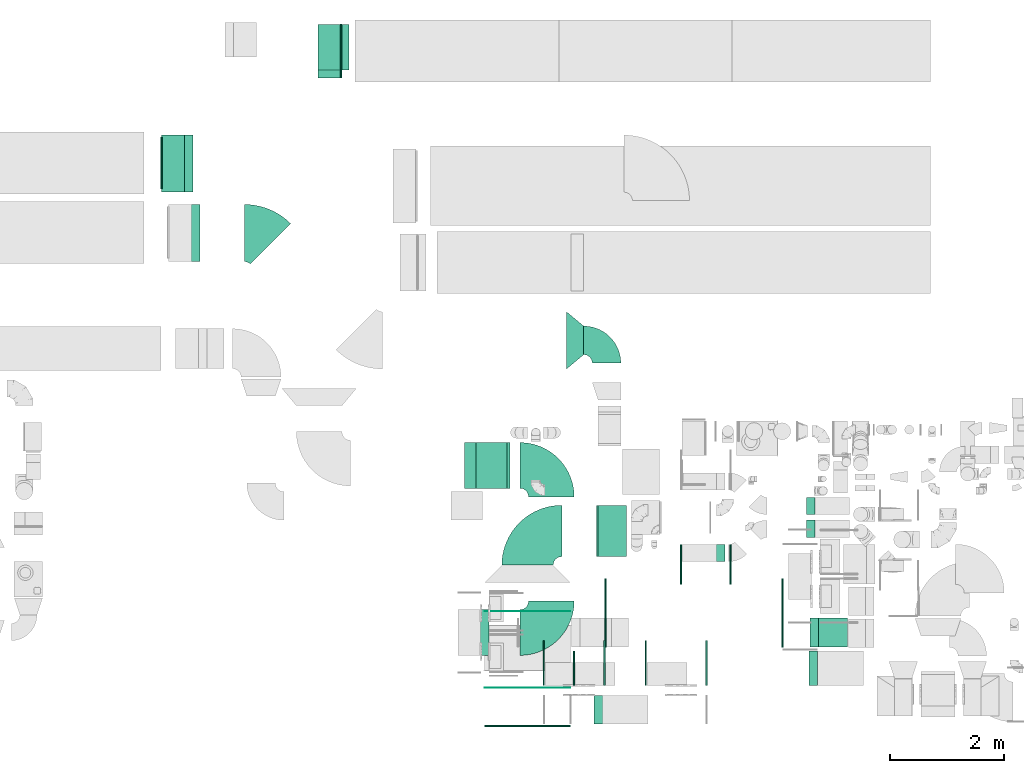
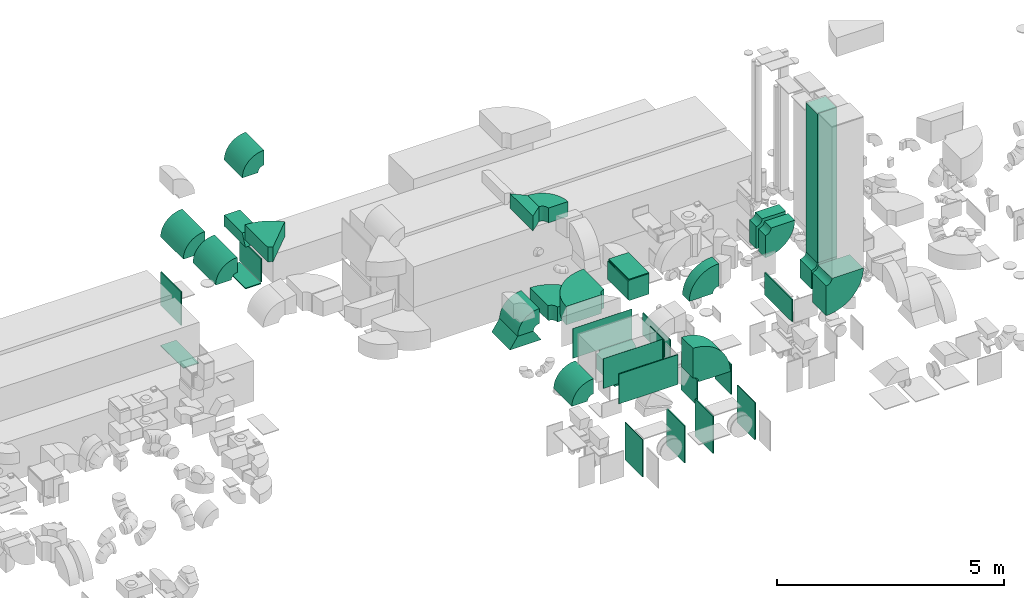
# One storey, part 3 of 59: 37 flow fittings, 1 flow segment.
"""IFC2X3 building model written with IfcOpenShell, lengths in millimetres."""

from ifc_helpers import new_model, entity, si_unit, converted_unit, derived_unit, direction, frame, frame_2d, origin, origin_2d_with_axis, place, context, subcontext, project, spatial, polyline, circle_curve, parameter, trimmed, segment, composite_curve, rectangle, outline, extrude, source, transform, mapped, material, type_object, type_shapes, element, save


model = new_model("IFC2X3")

# Units and contexts
model_context = context("Model", 3, precision=0.01, world=origin(), true_north=direction((6.12303176911189e-17, 1.0)))
body_context = subcontext(model_context, "Body", "Model", "MODEL_VIEW")
ifc_project = project(units=[si_unit("LENGTHUNIT", "METRE", prefix="MILLI"), si_unit("AREAUNIT", "SQUARE_METRE"), si_unit("VOLUMEUNIT", "CUBIC_METRE"), converted_unit("PLANEANGLEUNIT", "DEGREE", entity("IfcRatioMeasure", 0.0174532925199433), si_unit("PLANEANGLEUNIT", "RADIAN"), dimensions=[0, 0, 0, 0, 0, 0, 0]), si_unit("MASSUNIT", "GRAM", prefix="KILO"), derived_unit("MASSDENSITYUNIT", [(si_unit("MASSUNIT", "GRAM", prefix="KILO"), 1), (si_unit("LENGTHUNIT", "METRE"), -3)]), derived_unit("MOMENTOFINERTIAUNIT", [(si_unit("LENGTHUNIT", "METRE"), 4)]), si_unit("TIMEUNIT", "SECOND"), si_unit("FREQUENCYUNIT", "HERTZ"), si_unit("THERMODYNAMICTEMPERATUREUNIT", "DEGREE_CELSIUS"), derived_unit("THERMALTRANSMITTANCEUNIT", [(si_unit("MASSUNIT", "GRAM", prefix="KILO"), 1), (si_unit("THERMODYNAMICTEMPERATUREUNIT", "KELVIN"), -1), (si_unit("TIMEUNIT", "SECOND"), -3)]), derived_unit("VOLUMETRICFLOWRATEUNIT", [(si_unit("LENGTHUNIT", "METRE"), 3), (si_unit("TIMEUNIT", "SECOND"), -1)]), derived_unit("MASSFLOWRATEUNIT", [(si_unit("MASSUNIT", "GRAM", prefix="KILO"), 1), (si_unit("TIMEUNIT", "SECOND"), -1)]), derived_unit("ROTATIONALFREQUENCYUNIT", [(si_unit("TIMEUNIT", "SECOND"), -1)]), si_unit("ELECTRICCURRENTUNIT", "AMPERE"), si_unit("ELECTRICVOLTAGEUNIT", "VOLT"), si_unit("POWERUNIT", "WATT"), si_unit("FORCEUNIT", "NEWTON", prefix="KILO"), si_unit("ILLUMINANCEUNIT", "LUX"), si_unit("LUMINOUSFLUXUNIT", "LUMEN"), si_unit("LUMINOUSINTENSITYUNIT", "CANDELA"), derived_unit("USERDEFINED", [(si_unit("MASSUNIT", "GRAM", prefix="KILO"), -1), (si_unit("LENGTHUNIT", "METRE"), -2), (si_unit("TIMEUNIT", "SECOND"), 3), (si_unit("LUMINOUSFLUXUNIT", "LUMEN"), 1)]), derived_unit("LINEARVELOCITYUNIT", [(si_unit("LENGTHUNIT", "METRE"), 1), (si_unit("TIMEUNIT", "SECOND"), -1)]), si_unit("PRESSUREUNIT", "PASCAL"), derived_unit("USERDEFINED", [(si_unit("LENGTHUNIT", "METRE"), -2), (si_unit("MASSUNIT", "GRAM", prefix="KILO"), 1), (si_unit("TIMEUNIT", "SECOND"), -2)]), derived_unit("LINEARFORCEUNIT", [(si_unit("MASSUNIT", "GRAM", prefix="KILO"), 1), (si_unit("LENGTHUNIT", "METRE"), 1), (si_unit("TIMEUNIT", "SECOND"), -2), (si_unit("LENGTHUNIT", "METRE"), -1)]), derived_unit("PLANARFORCEUNIT", [(si_unit("MASSUNIT", "GRAM", prefix="KILO"), 1), (si_unit("LENGTHUNIT", "METRE"), 1), (si_unit("TIMEUNIT", "SECOND"), -2), (si_unit("LENGTHUNIT", "METRE"), -2)])], contexts=[model_context])

# Site, building, storey
site_placement = place(None, origin())
site = spatial("IfcSite", under=ifc_project, at=site_placement, CompositionType="ELEMENT")
building_placement = place(site_placement, origin())
building = spatial("IfcBuilding", under=site, at=building_placement, CompositionType="ELEMENT")
storey_placement = place(building_placement, frame((0.0, 0.0, 28200.0)))
storey = spatial("IfcBuildingStorey", under=building, at=storey_placement, CompositionType="ELEMENT", Elevation=28200.0)

# Flow segment
duct_segment_type = type_object("IfcDuctSegmentType", PredefinedType="NOTDEFINED")
flow_segment_placement = place(storey_placement, frame((48285.0, 9223.67, 3850.0)))
element("IfcFlowSegment", 1, at=flow_segment_placement, inside=storey, type_object=duct_segment_type, context=body_context, shape_type="SweptSolid", body=[
    extrude(rectangle(XDim=500.000000000008, YDim=500.0, at=origin_2d_with_axis()), frame((250.0, 250.0, 0.0), z_axis=(0.0, 0.0, 1.0), x_axis=(-1.0, 0.0, 0.0)), (0.0, 0.0, 1.0), 4000.00000000001),
])

# Flow fittings
ifc_material = material()
duct_fitting_type_1 = type_object("IfcDuctFittingType", PredefinedType="NOTDEFINED", material=ifc_material)
shared_shape_1 = source(origin(), body_context, "Body", "SweptSolid", [
    extrude(rectangle(XDim=24.9999999999999, YDim=400.0, at=origin_2d_with_axis()), frame((12.5, 0.0, -500.0)), (0.0, 0.0, 1.0), 1000.0),
])
type_shapes(duct_fitting_type_1, [shared_shape_1])
flow_fitting_1_placement = place(storey_placement, frame((36980.03, 17684.6, 236.05), z_axis=(0.0, -1.0, 0.0), x_axis=(0.0, 0.0, -1.0)))
element("IfcFlowFitting", 2, at=flow_fitting_1_placement, inside=storey, type_object=duct_fitting_type_1, material=ifc_material, context=body_context, shape_type="MappedRepresentation", body=[
    mapped(shared_shape_1, transform((0.0, 0.0, 0.0), scale=1.0)),
])
duct_fitting_type_2 = type_object("IfcDuctFittingType", PredefinedType="NOTDEFINED", material=ifc_material)
shared_shape_2 = source(origin(), body_context, "Body", "SweptSolid", [
    extrude(outline(polyline([(-435.33, -288.08), (-44.81, -288.08), (275.28, 96.03), (204.86, 480.14), (-435.33, -288.08)])), frame((150.0, 0.0, -200.0), z_axis=(0.0, 0.0, 1.0), x_axis=(0.768221279597377, 0.640184399664479, 0.0)), (0.0, 0.0, 1.0), 400.0),
])
type_shapes(duct_fitting_type_2, [shared_shape_2])
flow_fitting_2_placement = place(storey_placement, frame((43870.31, 14589.12, 3500.0)))
element("IfcFlowFitting", 3, at=flow_fitting_2_placement, inside=storey, type_object=duct_fitting_type_2, material=ifc_material, context=body_context, shape_type="MappedRepresentation", body=[
    mapped(shared_shape_2, transform((0.0, 0.0, 0.0), scale=1.0)),
])
duct_fitting_type_3 = type_object("IfcDuctFittingType", PredefinedType="NOTDEFINED", material=ifc_material)
shared_shape_3 = source(origin(), body_context, "Body", "SweptSolid", [
    extrude(rectangle(XDim=24.9999999999999, YDim=1500.0, at=origin_2d_with_axis()), frame((12.5, 0.0, -400.0)), (0.0, 0.0, 1.0), 800.0),
])
type_shapes(duct_fitting_type_3, [shared_shape_3])
flow_fitting_3_placement = place(storey_placement, frame((43185.45, 7846.66, 3360.0), z_axis=(0.0, 0.0, 1.0), x_axis=(0.0, -1.0, 0.0)))
element("IfcFlowFitting", 4, at=flow_fitting_3_placement, inside=storey, type_object=duct_fitting_type_3, material=ifc_material, context=body_context, shape_type="MappedRepresentation", body=[
    mapped(shared_shape_3, transform((0.0, 0.0, 0.0), scale=1.0)),
])
duct_fitting_type_4 = type_object("IfcDuctFittingType", PredefinedType="NOTDEFINED", material=ifc_material)
shared_shape_4 = source(origin(), body_context, "Body", "SweptSolid", [
    extrude(rectangle(XDim=6.0, YDim=1500.0, at=origin_2d_with_axis()), frame((0.0, 0.0, -400.0), z_axis=(0.0, 0.0, 1.0), x_axis=(-1.0, 0.0, 0.0)), (0.0, 0.0, 1.0), 800.0),
])
type_shapes(duct_fitting_type_4, [shared_shape_4])
for number, where, z_axis, x_axis in (
    (5, (43185.45, 9846.66, 3360.0), (0.0, 0.0, 1.0), (0.0, -1.0, 0.0)),
    (6, (43185.45, 8506.66, 3360.0), (0.0, 0.0, 1.0), (0.0, -1.0, 0.0)),
):
    element("IfcFlowFitting", number, at=place(storey_placement, frame(where, z_axis=z_axis, x_axis=x_axis)), inside=storey, type_object=duct_fitting_type_4, material=ifc_material, context=body_context, shape_type="MappedRepresentation", body=[
        mapped(shared_shape_4, transform((0.0, 0.0, 0.0), scale=1.0)),
    ])
duct_fitting_type_5 = type_object("IfcDuctFittingType", PredefinedType="NOTDEFINED", material=ifc_material)
shared_shape_5 = source(origin(), body_context, "Body", "SweptSolid", [
    extrude(rectangle(XDim=24.9999999999999, YDim=700.0, at=origin_2d_with_axis()), frame((12.5, 0.0, -400.0)), (0.0, 0.0, 1.0), 800.0),
])
type_shapes(duct_fitting_type_5, [shared_shape_5])
flow_fitting_4_placement = place(storey_placement, frame((46724.94, 10664.6, 600.0)))
element("IfcFlowFitting", 7, at=flow_fitting_4_placement, inside=storey, type_object=duct_fitting_type_5, material=ifc_material, context=body_context, shape_type="MappedRepresentation", body=[
    mapped(shared_shape_5, transform((0.0, 0.0, 0.0), scale=1.0)),
])
flow_fitting_5_placement = place(storey_placement, frame((45884.94, 10664.6, 600.0), z_axis=(0.0, 0.0, 1.0), x_axis=(-1.0, 0.0, 0.0)))
element("IfcFlowFitting", 8, at=flow_fitting_5_placement, inside=storey, type_object=duct_fitting_type_5, material=ifc_material, context=body_context, shape_type="MappedRepresentation", body=[
    mapped(shared_shape_5, transform((0.0, 0.0, 0.0), scale=1.0)),
])
duct_fitting_type_6 = type_object("IfcDuctFittingType", PredefinedType="NOTDEFINED", material=ifc_material)
shared_shape_6 = source(origin(), body_context, "Body", "SweptSolid", [
    extrude(rectangle(XDim=24.9999999999999, YDim=1000.0, at=origin_2d_with_axis()), frame((12.5, 0.0, -390.0)), (0.0, 0.0, 1.0), 780.0),
])
type_shapes(duct_fitting_type_6, [shared_shape_6])
for number, where, z_axis, x_axis in (
    (9, (46308.79, 8939.6, 700.0), (0.0, 1.0, 0.0), (1.0, 0.0, 0.0)),
    (10, (45268.79, 8939.6, 700.0), (0.0, 1.0, 0.0), (-1.0, 0.0, 0.0)),
    (11, (44522.17, 8939.6, 700.0), (0.0, 1.0, 0.0), (1.0, 0.0, 0.0)),
    (12, (43482.17, 8939.6, 700.0), (0.0, 1.0, 0.0), (-1.0, 0.0, 0.0)),
):
    element("IfcFlowFitting", number, at=place(storey_placement, frame(where, z_axis=z_axis, x_axis=x_axis)), inside=storey, type_object=duct_fitting_type_6, material=ifc_material, context=body_context, shape_type="MappedRepresentation", body=[
        mapped(shared_shape_6, transform((0.0, 0.0, 0.0), scale=1.0)),
    ])
duct_fitting_type_7 = type_object("IfcDuctFittingType", PredefinedType="NOTDEFINED", material=ifc_material)
shared_shape_7 = source(origin(), body_context, "Body", "SweptSolid", [
    extrude(rectangle(XDim=24.9999999999999, YDim=600.0, at=origin_2d_with_axis()), frame((12.5, 0.0, -400.0)), (0.0, 0.0, 1.0), 800.0),
])
type_shapes(duct_fitting_type_7, [shared_shape_7])
flow_fitting_6_placement = place(storey_placement, frame((44012.75, 8849.6, 3300.0), z_axis=(0.0, 0.0, 1.0), x_axis=(-1.0, 0.0, 0.0)))
element("IfcFlowFitting", 13, at=flow_fitting_6_placement, inside=storey, type_object=duct_fitting_type_7, material=ifc_material, context=body_context, shape_type="MappedRepresentation", body=[
    mapped(shared_shape_7, transform((0.0, 0.0, 0.0), scale=1.0)),
])
duct_fitting_type_8 = type_object("IfcDuctFittingType", PredefinedType="NOTDEFINED", material=ifc_material)
shared_shape_8 = source(origin(), body_context, "Body", "SweptSolid", [
    extrude(rectangle(XDim=24.9999999999999, YDim=1200.0, at=origin_2d_with_axis()), frame((12.5, 0.0, -300.0)), (0.0, 0.0, 1.0), 600.0),
])
type_shapes(duct_fitting_type_8, [shared_shape_8])
flow_fitting_7_placement = place(storey_placement, frame((44564.13, 9814.73, 2800.0), z_axis=(0.0, 0.0, 1.0), x_axis=(-1.0, 0.0, 0.0)))
element("IfcFlowFitting", 14, at=flow_fitting_7_placement, inside=storey, type_object=duct_fitting_type_8, material=ifc_material, context=body_context, shape_type="MappedRepresentation", body=[
    mapped(shared_shape_8, transform((0.0, 0.0, 0.0), scale=1.0)),
])
duct_fitting_type_9 = type_object("IfcDuctFittingType", PredefinedType="NOTDEFINED", material=ifc_material)
shared_shape_9 = source(origin(), body_context, "Body", "SweptSolid", [
    extrude(rectangle(XDim=26.0960000000019, YDim=1200.0, at=origin_2d_with_axis()), frame((6.95, 0.0, -300.0)), (0.0, 0.0, 1.0), 600.0),
])
type_shapes(duct_fitting_type_9, [shared_shape_9])
flow_fitting_8_placement = place(storey_placement, frame((47655.88, 9814.73, 2800.0), z_axis=(0.0, 0.0, -1.0), x_axis=(-1.0, 0.0, 0.0)))
element("IfcFlowFitting", 15, at=flow_fitting_8_placement, inside=storey, type_object=duct_fitting_type_9, material=ifc_material, context=body_context, shape_type="MappedRepresentation", body=[
    mapped(shared_shape_9, transform((0.0, 0.0, 0.0), scale=1.0)),
])
duct_fitting_type_10 = type_object("IfcDuctFittingType", PredefinedType="NOTDEFINED", material=ifc_material)
shared_shape_10 = source(origin(), body_context, "Body", "SweptSolid", [
    extrude(outline(polyline([(-150.0, -434.5), (150.0, -434.5), (150.0, 503.5), (-150.0, 365.5), (-150.0, -434.5)])), frame((150.0, -200.0, -34.5), z_axis=(0.0, 1.0, 0.0), x_axis=(1.0, 0.0, 0.0)), (0.0, 0.0, 1.0), 400.0),
])
type_shapes(duct_fitting_type_10, [shared_shape_10])
flow_fitting_9_placement = place(storey_placement, frame((39713.7, 19723.62, 1600.0), z_axis=(0.0, 1.0, 0.0), x_axis=(0.0, 0.0, -1.0)))
element("IfcFlowFitting", 16, at=flow_fitting_9_placement, inside=storey, type_object=duct_fitting_type_10, material=ifc_material, context=body_context, shape_type="MappedRepresentation", body=[
    mapped(shared_shape_10, transform((0.0, 0.0, 0.0), scale=1.0)),
])
duct_fitting_type_11 = type_object("IfcDuctFittingType", PredefinedType="NOTDEFINED", material=ifc_material)
shared_shape_11 = source(origin(), body_context, "Body", "SweptSolid", [
    extrude(rectangle(XDim=26.0960000003908, YDim=618.0, at=origin_2d_with_axis()), frame((6.95, 0.0, -469.0)), (0.0, 0.0, 1.0), 938.0),
])
type_shapes(duct_fitting_type_11, [shared_shape_11])
flow_fitting_10_placement = place(storey_placement, frame((39913.7, 19654.62, 535.0), z_axis=(0.0, -1.0, 0.0), x_axis=(1.0, 0.0, 0.0)))
element("IfcFlowFitting", 17, at=flow_fitting_10_placement, inside=storey, type_object=duct_fitting_type_11, material=ifc_material, context=body_context, shape_type="MappedRepresentation", body=[
    mapped(shared_shape_11, transform((0.0, 0.0, 0.0), scale=1.0)),
])
duct_fitting_type_12 = type_object("IfcDuctFittingType", PredefinedType="NOTDEFINED", material=ifc_material)
shared_shape_12 = source(origin(), body_context, "Body", "SweptSolid", [
    extrude(rectangle(XDim=24.9999999999999, YDim=400.0, at=origin_2d_with_axis()), frame((12.5, 0.0, -469.0)), (0.0, 0.0, 1.0), 938.0),
])
type_shapes(duct_fitting_type_12, [shared_shape_12])
flow_fitting_11_placement = place(storey_placement, frame((39713.7, 19654.62, 200.0), z_axis=(0.0, 1.0, 0.0), x_axis=(0.0, 0.0, -1.0)))
element("IfcFlowFitting", 18, at=flow_fitting_11_placement, inside=storey, type_object=duct_fitting_type_12, material=ifc_material, context=body_context, shape_type="MappedRepresentation", body=[
    mapped(shared_shape_12, transform((0.0, 0.0, 0.0), scale=1.0)),
])
duct_fitting_type_13 = type_object("IfcDuctFittingType", PredefinedType="NOTDEFINED", material=ifc_material)
shared_shape_13 = source(origin(), body_context, "Body", "SweptSolid", [
    extrude(outline(polyline([(-13.87, -249.62), (346.69, -249.62), (-97.07, 416.03), (-235.75, 83.21), (-13.87, -249.62)])), frame((150.0, -400.0, 0.0), z_axis=(0.0, 1.0, 0.0), x_axis=(0.832050294337883, 0.0, 0.554700196225171)), (0.0, 0.0, 1.0), 800.0),
])
type_shapes(duct_fitting_type_13, [shared_shape_13])
flow_fitting_12_placement = place(storey_placement, frame((42480.17, 12399.85, 2300.0), z_axis=(-1.0, 0.0, 0.0), x_axis=(0.0, 0.0, -1.0)))
element("IfcFlowFitting", 19, at=flow_fitting_12_placement, inside=storey, type_object=duct_fitting_type_13, material=ifc_material, context=body_context, shape_type="MappedRepresentation", body=[
    mapped(shared_shape_13, transform((0.0, 0.0, 0.0), scale=1.0)),
])
duct_fitting_type_14 = type_object("IfcDuctFittingType", PredefinedType="NOTDEFINED", material=ifc_material)
shared_shape_14 = source(origin(), body_context, "Body", "SweptSolid", [
    extrude(outline(polyline([(-275.0, 118.75), (-275.0, -381.25), (275.0, -381.25), (275.0, 118.75), (250.0, 118.75), (250.0, 143.75), (-250.0, 143.75), (-250.0, 118.75), (-275.0, 118.75)])), frame((0.0, -131.25, -450.0), z_axis=(0.0, 0.0, -1.0), x_axis=(1.0, 0.0, 0.0)), (0.0, 0.0, -1.0), 900.0),
])
type_shapes(duct_fitting_type_14, [shared_shape_14])
flow_fitting_13_placement = place(storey_placement, frame((44668.87, 11251.83, 3510.0), z_axis=(0.0, -1.0, 0.0), x_axis=(0.0, 0.0, -1.0)))
element("IfcFlowFitting", 20, at=flow_fitting_13_placement, inside=storey, type_object=duct_fitting_type_14, material=ifc_material, context=body_context, shape_type="MappedRepresentation", body=[
    mapped(shared_shape_14, transform((0.0, 0.0, 0.0), scale=1.0)),
])
duct_fitting_type_15 = type_object("IfcDuctFittingType", PredefinedType="NOTDEFINED", material=ifc_material)
shared_shape_15 = source(origin(), body_context, "Body", "SweptSolid", [
    extrude(rectangle(XDim=24.9999999999999, YDim=500.0, at=origin_2d_with_axis()), frame((12.5, 0.0, -450.0)), (0.0, 0.0, 1.0), 900.0),
])
type_shapes(duct_fitting_type_15, [shared_shape_15])
flow_fitting_14_placement = place(storey_placement, frame((44668.87, 11251.83, 3785.0), z_axis=(0.0, -1.0, 0.0), x_axis=(0.0, 0.0, 1.0)))
element("IfcFlowFitting", 21, at=flow_fitting_14_placement, inside=storey, type_object=duct_fitting_type_15, material=ifc_material, context=body_context, shape_type="MappedRepresentation", body=[
    mapped(shared_shape_15, transform((0.0, 0.0, 0.0), scale=1.0)),
])
duct_fitting_type_16 = type_object("IfcDuctFittingType", PredefinedType="NOTDEFINED", material=ifc_material)
shared_shape_16 = source(origin(), body_context, "Body", "SweptSolid", [
    extrude(rectangle(XDim=900.0, YDim=26.0982283724435, at=origin_2d_with_axis()), frame((6.95, 0.0, -450.0), z_axis=(0.0, 0.0, 1.0), x_axis=(0.0, -1.0, 0.0)), (0.0, 0.0, 1.0), 900.0),
])
type_shapes(duct_fitting_type_16, [shared_shape_16])
flow_fitting_15_placement = place(storey_placement, frame((36780.03, 17694.61, 1785.0), z_axis=(2.47596938470529e-06, 1.0, 0.0), x_axis=(-1.0, 2.47596937398128e-06, 0.0)))
element("IfcFlowFitting", 22, at=flow_fitting_15_placement, inside=storey, type_object=duct_fitting_type_16, material=ifc_material, context=body_context, shape_type="MappedRepresentation", body=[
    mapped(shared_shape_16, transform((0.0, 0.0, 0.0), scale=1.0)),
])
duct_fitting_type_17 = type_object("IfcDuctFittingType", PredefinedType="NOTDEFINED", material=ifc_material)
shared_shape_17 = source(origin(), body_context, "Body", "SweptSolid", [
    extrude(outline(composite_curve([segment(polyline([(-675.0, -275.0), (125.0, -275.0)]), True, "CONTINUOUS"), segment(trimmed(circle_curve(frame_2d((275.0, -275.0), x_axis=(0.0, 1.0)), 150.0), [parameter(0.0)], [parameter(90.0000000000001)], True, "PARAMETER"), False, "CONTINUOUS"), segment(polyline([(275.0, -125.0), (275.0, 675.0)]), True, "CONTINUOUS"), segment(trimmed(circle_curve(frame_2d((275.0, -275.0), x_axis=(0.0, 1.0)), 950.0), [parameter(0.0)], [parameter(90.0000000000001)], True, "PARAMETER"), True, "CONTINUOUS")], self_intersect=False)), frame((-275.0, 275.0, -200.0), z_axis=(0.0, 0.0, 1.0), x_axis=(-1.0, 0.0, 0.0)), (0.0, 0.0, 1.0), 400.0),
])
type_shapes(duct_fitting_type_17, [shared_shape_17])
flow_fitting_16_placement = place(storey_placement, frame((43602.86, 9473.67, 2650.0)))
element("IfcFlowFitting", 23, at=flow_fitting_16_placement, inside=storey, type_object=duct_fitting_type_17, material=ifc_material, context=body_context, shape_type="MappedRepresentation", body=[
    mapped(shared_shape_17, transform((0.0, 0.0, 0.0), scale=1.0)),
])
flow_fitting_17_placement = place(storey_placement, frame((43602.86, 12399.85, 2650.0), z_axis=(0.0, 1.36897944153772e-08, 1.0), x_axis=(0.0, 1.0, -1.36897944153772e-08)))
element("IfcFlowFitting", 24, at=flow_fitting_17_placement, inside=storey, type_object=duct_fitting_type_17, material=ifc_material, context=body_context, shape_type="MappedRepresentation", body=[
    mapped(shared_shape_17, transform((0.0, 0.0, 0.0), scale=1.0)),
])
duct_fitting_type_18 = type_object("IfcDuctFittingType", PredefinedType="NOTDEFINED", material=ifc_material)
shared_shape_18 = source(origin(), body_context, "Body", "SweptSolid", [
    extrude(outline(composite_curve([segment(polyline([(-525.0, -225.0), (75.0, -225.0)]), True, "CONTINUOUS"), segment(trimmed(circle_curve(frame_2d((225.0, -225.0), x_axis=(0.0, 1.0)), 150.0), [parameter(0.0)], [parameter(90.0)], True, "PARAMETER"), False, "CONTINUOUS"), segment(polyline([(225.0, -75.0), (225.0, 525.0)]), True, "CONTINUOUS"), segment(trimmed(circle_curve(frame_2d((225.0, -225.0), x_axis=(0.0, 1.0)), 750.0), [parameter(0.0)], [parameter(90.0)], True, "PARAMETER"), True, "CONTINUOUS")], self_intersect=False)), frame((-225.0, 225.0, -150.0), z_axis=(0.0, 0.0, 1.0), x_axis=(-1.0, 0.0, 0.0)), (0.0, 0.0, 1.0), 300.0),
])
type_shapes(duct_fitting_type_18, [shared_shape_18])
for number, where, z_axis, x_axis in (
    (25, (46194.5, 10864.6, 3200.0), (0.0, -1.0, 0.0), (-1.0, 0.0, 0.0)),
    (26, (48520.03, 11289.6, 3200.0), (0.0, -1.0, 0.0), (1.0, 0.0, 0.0)),
    (27, (48520.03, 11689.6, 3200.0), (0.0, -1.0, 0.0), (1.0, 0.0, 0.0)),
):
    element("IfcFlowFitting", number, at=place(storey_placement, frame(where, z_axis=z_axis, x_axis=x_axis)), inside=storey, type_object=duct_fitting_type_18, material=ifc_material, context=body_context, shape_type="MappedRepresentation", body=[
        mapped(shared_shape_18, transform((0.0, 0.0, 0.0), scale=1.0)),
    ])
duct_fitting_type_19 = type_object("IfcDuctFittingType", PredefinedType="NOTDEFINED", material=ifc_material)
shared_shape_19 = source(origin(), body_context, "Body", "SweptSolid", [
    extrude(outline(composite_curve([segment(polyline([(-375.0, -175.0), (25.0, -175.0)]), True, "CONTINUOUS"), segment(trimmed(circle_curve(frame_2d((175.0, -175.0), x_axis=(0.0, 1.0)), 150.0), [parameter(0.0)], [parameter(90.0000000000001)], True, "PARAMETER"), False, "CONTINUOUS"), segment(polyline([(175.0, -25.0), (175.0, 375.0)]), True, "CONTINUOUS"), segment(trimmed(circle_curve(frame_2d((175.0, -175.0), x_axis=(0.0, 1.0)), 550.0), [parameter(0.0)], [parameter(90.0)], True, "PARAMETER"), True, "CONTINUOUS")], self_intersect=False)), frame((-175.0, 175.0, -500.0), z_axis=(0.0, 0.0, 1.0), x_axis=(-1.0, 0.0, 0.0)), (0.0, 0.0, 1.0), 1000.0),
])
type_shapes(duct_fitting_type_19, [shared_shape_19])
flow_fitting_18_placement = place(storey_placement, frame((36980.03, 17684.6, 3500.0), z_axis=(0.0, 1.0, 0.0), x_axis=(0.0, 0.0, 1.0)))
element("IfcFlowFitting", 28, at=flow_fitting_18_placement, inside=storey, type_object=duct_fitting_type_19, material=ifc_material, context=body_context, shape_type="MappedRepresentation", body=[
    mapped(shared_shape_19, transform((0.0, 0.0, 0.0), scale=1.0)),
])
duct_fitting_type_20 = type_object("IfcDuctFittingType", PredefinedType="NOTDEFINED", material=ifc_material)
shared_shape_20 = source(origin(), body_context, "Body", "SweptSolid", [
    extrude(outline(composite_curve([segment(polyline([(-375.0, -175.0), (25.0, -175.0)]), True, "CONTINUOUS"), segment(trimmed(circle_curve(frame_2d((175.0, -175.0), x_axis=(2.93734103706811e-08, 1.0)), 150.0), [parameter(0.0)], [parameter(90.0000016829736)], True, "PARAMETER"), False, "CONTINUOUS"), segment(polyline([(175.0, -25.0), (175.0, 375.0)]), True, "CONTINUOUS"), segment(trimmed(circle_curve(frame_2d((175.0, -175.0), x_axis=(2.93734103706811e-08, 1.0)), 550.0), [parameter(0.0)], [parameter(90.0000016829736)], True, "PARAMETER"), True, "CONTINUOUS")], self_intersect=False)), frame((-175.0, 175.0, -500.0), z_axis=(0.0, 0.0, 1.0), x_axis=(-1.0, -2.93734300775839e-08, 0.0)), (0.0, 0.0, 1.0), 1000.0),
])
type_shapes(duct_fitting_type_20, [shared_shape_20])
flow_fitting_19_placement = place(storey_placement, frame((37100.03, 16469.6, 3500.0), z_axis=(0.0, 1.0, 0.0), x_axis=(0.0, 0.0, 1.0)))
element("IfcFlowFitting", 29, at=flow_fitting_19_placement, inside=storey, type_object=duct_fitting_type_20, material=ifc_material, context=body_context, shape_type="MappedRepresentation", body=[
    mapped(shared_shape_20, transform((0.0, 0.0, 0.0), scale=1.0)),
])
duct_fitting_type_21 = type_object("IfcDuctFittingType", PredefinedType="NOTDEFINED", material=ifc_material)
shared_shape_21 = source(origin(), body_context, "Body", "SweptSolid", [
    extrude(outline(composite_curve([segment(polyline([(-595.19, -229.81), (404.81, -229.81)]), True, "CONTINUOUS"), segment(trimmed(circle_curve(frame_2d((554.81, -229.81), x_axis=(-0.707106781186553, 0.707106781186553)), 150.0), [parameter(0.0)], [parameter(45.0)], True, "PARAMETER"), False, "CONTINUOUS"), segment(polyline([(448.74, -123.74), (-258.36, 583.36)]), True, "CONTINUOUS"), segment(trimmed(circle_curve(frame_2d((554.81, -229.81), x_axis=(-0.707106781186553, 0.707106781186553)), 1150.0), [parameter(0.0)], [parameter(45.0)], True, "PARAMETER"), True, "CONTINUOUS")], self_intersect=False)), frame((-39.43, 95.19, -200.0), z_axis=(0.0, 0.0, 1.0), x_axis=(-0.707106781186547, 0.707106781186548, 0.0)), (0.0, 0.0, 1.0), 400.0),
])
type_shapes(duct_fitting_type_21, [shared_shape_21])
flow_fitting_20_placement = place(storey_placement, frame((38495.38, 16469.6, 3500.0), z_axis=(2.93734299762197e-08, 2.93734299762191e-08, 1.0), x_axis=(-0.707106781186541, 0.707106781186554, 0.0)))
element("IfcFlowFitting", 30, at=flow_fitting_20_placement, inside=storey, type_object=duct_fitting_type_21, material=ifc_material, context=body_context, shape_type="MappedRepresentation", body=[
    mapped(shared_shape_21, transform((0.0, 0.0, 0.0), scale=1.0)),
])
duct_fitting_type_22 = type_object("IfcDuctFittingType", PredefinedType="NOTDEFINED", material=ifc_material)
shared_shape_22 = source(origin(), body_context, "Body", "SweptSolid", [
    extrude(outline(composite_curve([segment(polyline([(-450.0, -200.0), (50.0, -200.0)]), True, "CONTINUOUS"), segment(trimmed(circle_curve(frame_2d((200.0, -200.0), x_axis=(0.0, 1.0)), 150.0), [parameter(0.0)], [parameter(90.0000000000001)], True, "PARAMETER"), False, "CONTINUOUS"), segment(polyline([(200.0, -50.0), (200.0, 450.0)]), True, "CONTINUOUS"), segment(trimmed(circle_curve(frame_2d((200.0, -200.0), x_axis=(0.0, 1.0)), 650.0), [parameter(0.0)], [parameter(90.0000000000001)], True, "PARAMETER"), True, "CONTINUOUS")], self_intersect=False)), frame((-200.0, 200.0, -200.0), z_axis=(0.0, 0.0, 1.0), x_axis=(-1.0, 0.0, 0.0)), (0.0, 0.0, 1.0), 400.0),
])
type_shapes(duct_fitting_type_22, [shared_shape_22])
flow_fitting_21_placement = place(storey_placement, frame((44570.31, 14589.12, 3500.0), z_axis=(0.0, 0.0, 1.0), x_axis=(0.0, 1.0, 0.0)))
element("IfcFlowFitting", 31, at=flow_fitting_21_placement, inside=storey, type_object=duct_fitting_type_22, material=ifc_material, context=body_context, shape_type="MappedRepresentation", body=[
    mapped(shared_shape_22, transform((0.0, 0.0, 0.0), scale=1.0)),
])
duct_fitting_type_23 = type_object("IfcDuctFittingType", PredefinedType="NOTDEFINED", material=ifc_material)
shared_shape_23 = source(origin(), body_context, "Body", "SweptSolid", [
    extrude(outline(composite_curve([segment(polyline([(-675.0, -275.0), (125.0, -275.0)]), True, "CONTINUOUS"), segment(trimmed(circle_curve(frame_2d((275.0, -275.0), x_axis=(0.0, 1.0)), 150.0), [parameter(0.0)], [parameter(90.0000000000001)], True, "PARAMETER"), False, "CONTINUOUS"), segment(polyline([(275.0, -125.0), (275.0, 675.0)]), True, "CONTINUOUS"), segment(trimmed(circle_curve(frame_2d((275.0, -275.0), x_axis=(0.0, 1.0)), 950.0), [parameter(0.0)], [parameter(90.0000000000001)], True, "PARAMETER"), True, "CONTINUOUS")], self_intersect=False)), frame((-275.0, 275.0, -250.0), z_axis=(0.0, 0.0, 1.0), x_axis=(-1.0, 0.0, 0.0)), (0.0, 0.0, 1.0), 500.0),
])
type_shapes(duct_fitting_type_23, [shared_shape_23])
flow_fitting_22_placement = place(storey_placement, frame((44898.71, 8124.6, 3351.2), z_axis=(0.0, 1.0, 0.0), x_axis=(1.0, 0.0, 0.0)))
element("IfcFlowFitting", 32, at=flow_fitting_22_placement, inside=storey, type_object=duct_fitting_type_23, material=ifc_material, context=body_context, shape_type="MappedRepresentation", body=[
    mapped(shared_shape_23, transform((0.0, 0.0, 0.0), scale=1.0)),
])
duct_fitting_type_24 = type_object("IfcDuctFittingType", PredefinedType="NOTDEFINED", material=ifc_material)
shared_shape_24 = source(origin(), body_context, "Body", "SweptSolid", [
    extrude(outline(composite_curve([segment(polyline([(-750.0, -300.0), (150.0, -300.0)]), True, "CONTINUOUS"), segment(trimmed(circle_curve(frame_2d((300.0, -300.0), x_axis=(0.0, 1.0)), 150.0), [parameter(0.0)], [parameter(90.0000000000001)], True, "PARAMETER"), False, "CONTINUOUS"), segment(polyline([(300.0, -150.0), (300.0, 750.0)]), True, "CONTINUOUS"), segment(trimmed(circle_curve(frame_2d((300.0, -300.0), x_axis=(0.0, 1.0)), 1050.0), [parameter(0.0)], [parameter(90.0)], True, "PARAMETER"), True, "CONTINUOUS")], self_intersect=False)), frame((-300.0, 300.0, -250.0), z_axis=(0.0, 0.0, 1.0), x_axis=(-1.0, 0.0, 0.0)), (0.0, 0.0, 1.0), 500.0),
])
type_shapes(duct_fitting_type_24, [shared_shape_24])
flow_fitting_23_placement = place(storey_placement, frame((43185.45, 11251.83, 3510.0), z_axis=(0.0, 0.0, 1.0), x_axis=(-1.0, 0.0, 0.0)))
element("IfcFlowFitting", 33, at=flow_fitting_23_placement, inside=storey, type_object=duct_fitting_type_24, material=ifc_material, context=body_context, shape_type="MappedRepresentation", body=[
    mapped(shared_shape_24, transform((0.0, 0.0, 0.0), scale=1.0)),
])
duct_fitting_type_25 = type_object("IfcDuctFittingType", PredefinedType="NOTDEFINED", material=ifc_material)
shared_shape_25 = source(origin(), body_context, "Body", "SweptSolid", [
    extrude(outline(composite_curve([segment(polyline([(-450.0, -200.0), (50.0, -200.0)]), True, "CONTINUOUS"), segment(trimmed(circle_curve(frame_2d((200.0, -200.0), x_axis=(0.0, 1.0)), 150.0), [parameter(0.0)], [parameter(90.0000000000001)], True, "PARAMETER"), False, "CONTINUOUS"), segment(polyline([(200.0, -50.0), (200.0, 450.0)]), True, "CONTINUOUS"), segment(trimmed(circle_curve(frame_2d((200.0, -200.0), x_axis=(0.0, 1.0)), 650.0), [parameter(0.0)], [parameter(90.0000000000001)], True, "PARAMETER"), True, "CONTINUOUS")], self_intersect=False)), frame((-200.0, 200.0, -250.0), z_axis=(0.0, 0.0, 1.0), x_axis=(-1.0, 0.0, 0.0)), (0.0, 0.0, 1.0), 500.0),
])
type_shapes(duct_fitting_type_25, [shared_shape_25])
flow_fitting_24_placement = place(storey_placement, frame((48535.0, 9473.67, 3450.0), z_axis=(0.0, -1.0, 0.0), x_axis=(1.0, 0.0, 0.0)))
element("IfcFlowFitting", 34, at=flow_fitting_24_placement, inside=storey, type_object=duct_fitting_type_25, material=ifc_material, context=body_context, shape_type="MappedRepresentation", body=[
    mapped(shared_shape_25, transform((0.0, 0.0, 0.0), scale=1.0)),
])
duct_fitting_type_26 = type_object("IfcDuctFittingType", PredefinedType="NOTDEFINED", material=ifc_material)
shared_shape_26 = source(origin(), body_context, "Body", "SweptSolid", [
    extrude(outline(composite_curve([segment(polyline([(-375.0, -175.0), (25.0, -175.0)]), True, "CONTINUOUS"), segment(trimmed(circle_curve(frame_2d((175.0, -175.0), x_axis=(0.0, 1.0)), 150.0), [parameter(0.0)], [parameter(90.0000000000001)], True, "PARAMETER"), False, "CONTINUOUS"), segment(polyline([(175.0, -25.0), (175.0, 375.0)]), True, "CONTINUOUS"), segment(trimmed(circle_curve(frame_2d((175.0, -175.0), x_axis=(0.0, 1.0)), 550.0), [parameter(0.0)], [parameter(90.0)], True, "PARAMETER"), True, "CONTINUOUS")], self_intersect=False)), frame((-175.0, 175.0, -400.0), z_axis=(0.0, 0.0, 1.0), x_axis=(-1.0, 0.0, 0.0)), (0.0, 0.0, 1.0), 800.0),
])
type_shapes(duct_fitting_type_26, [shared_shape_26])
for number, where, z_axis, x_axis in (
    (35, (42165.03, 9473.67, 2650.0), (0.0, -1.0, 0.0), (-1.0, 0.0, 0.0)),
    (36, (39713.7, 19723.62, 3430.26), (0.0, 1.0, 0.0), (0.0, 0.0, 1.0)),
    (37, (42480.17, 12399.85, 2650.0), (0.0, -1.0, 0.0), (-1.0, 0.0, 0.0)),
):
    element("IfcFlowFitting", number, at=place(storey_placement, frame(where, z_axis=z_axis, x_axis=x_axis)), inside=storey, type_object=duct_fitting_type_26, material=ifc_material, context=body_context, shape_type="MappedRepresentation", body=[
        mapped(shared_shape_26, transform((0.0, 0.0, 0.0), scale=1.0)),
    ])
duct_fitting_type_27 = type_object("IfcDuctFittingType", PredefinedType="NOTDEFINED", material=ifc_material)
shared_shape_27 = source(origin(), body_context, "Body", "SweptSolid", [
    extrude(outline(composite_curve([segment(polyline([(-675.0, -275.0), (125.0, -275.0)]), True, "CONTINUOUS"), segment(trimmed(circle_curve(frame_2d((275.0, -275.0), x_axis=(0.0, 1.0)), 150.0), [parameter(0.0)], [parameter(90.0)], True, "PARAMETER"), False, "CONTINUOUS"), segment(polyline([(275.0, -125.0), (275.0, 675.0)]), True, "CONTINUOUS"), segment(trimmed(circle_curve(frame_2d((275.0, -275.0), x_axis=(0.0, 1.0)), 950.0), [parameter(0.0)], [parameter(89.9999999999999)], True, "PARAMETER"), True, "CONTINUOUS")], self_intersect=False)), frame((-275.0, 275.0, -300.0), z_axis=(0.0, 0.0, 1.0), x_axis=(-1.0, 0.0, 0.0)), (0.0, 0.0, 1.0), 600.0),
])
type_shapes(duct_fitting_type_27, [shared_shape_27])
flow_fitting_25_placement = place(storey_placement, frame((48667.97, 8849.6, 3300.0), z_axis=(0.0, -1.0, 0.0), x_axis=(1.0, 0.0, 0.0)))
element("IfcFlowFitting", 38, at=flow_fitting_25_placement, inside=storey, type_object=duct_fitting_type_27, material=ifc_material, context=body_context, shape_type="MappedRepresentation", body=[
    mapped(shared_shape_27, transform((0.0, 0.0, 0.0), scale=1.0)),
])

save(model, "model.ifc")
